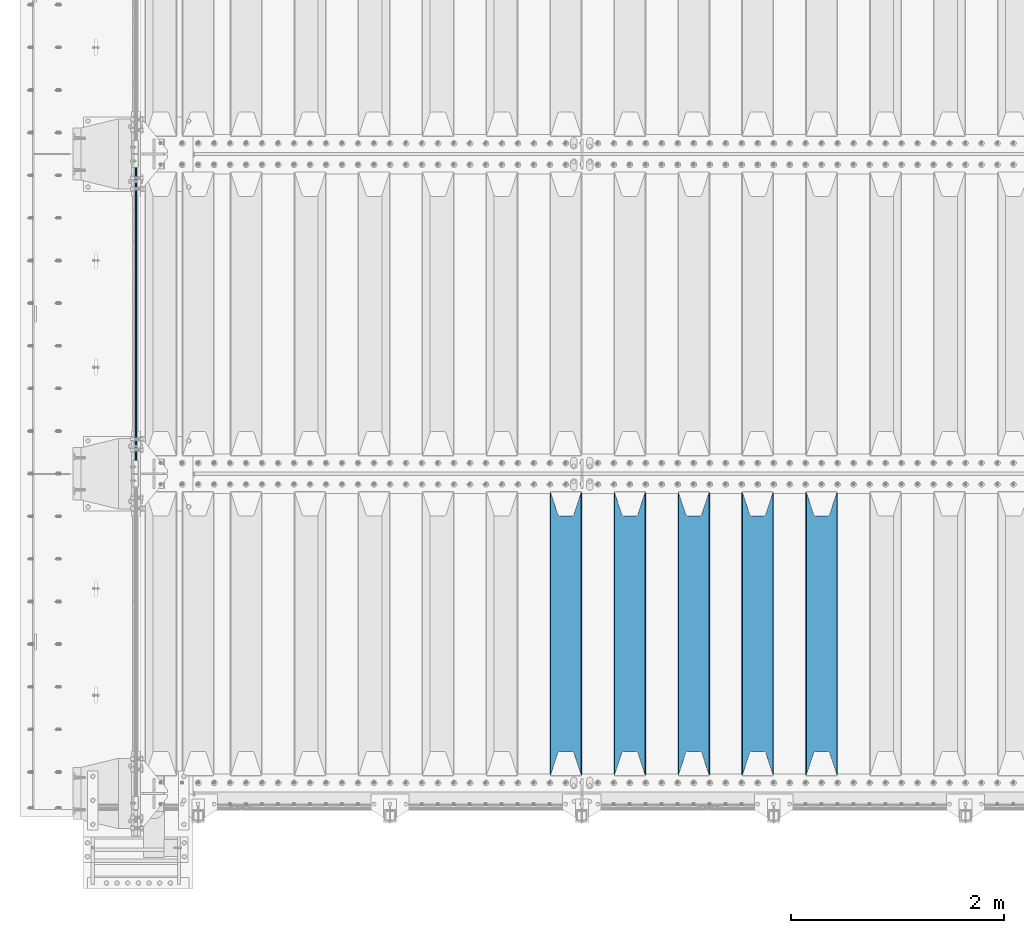
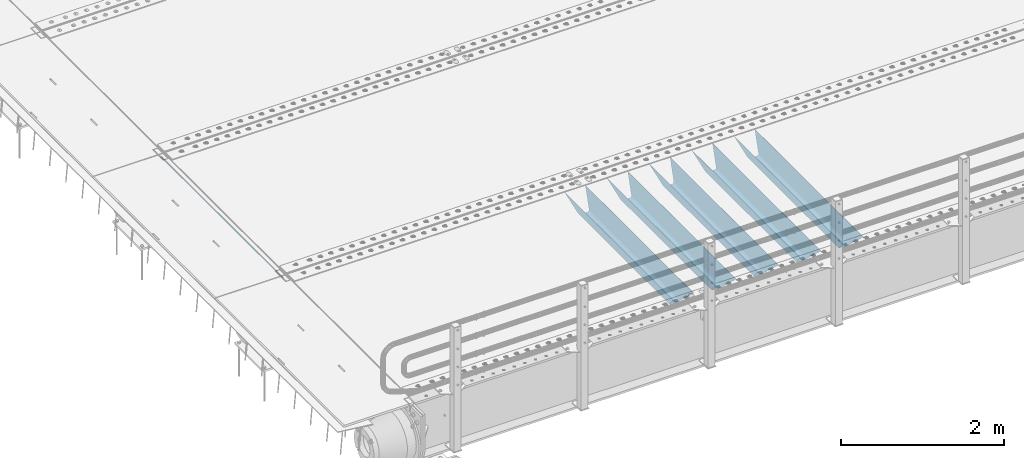
# One storey, part 101 of 240: 6 beams.
"""IFC2X3 building model written with IfcOpenShell, lengths in millimetres."""

from ifc_helpers import new_model, si_unit, frame, origin_with_axes, place, context, subcontext, project, spatial, faceted_brep, material, type_object, element, save


model = new_model("IFC2X3")

# Units and contexts
model_context = context("Model", 3, precision=1e-05, world=origin_with_axes())
body_context = subcontext(model_context, "Body", "Model", "MODEL_VIEW")
ifc_project = project(units=[si_unit("LENGTHUNIT", "METRE", prefix="MILLI"), si_unit("AREAUNIT", "SQUARE_METRE"), si_unit("VOLUMEUNIT", "CUBIC_METRE"), si_unit("MASSUNIT", "GRAM", prefix="KILO"), si_unit("TIMEUNIT", "SECOND"), si_unit("PLANEANGLEUNIT", "RADIAN"), si_unit("SOLIDANGLEUNIT", "STERADIAN"), si_unit("THERMODYNAMICTEMPERATUREUNIT", "DEGREE_CELSIUS"), si_unit("LUMINOUSINTENSITYUNIT", "LUMEN")], contexts=[model_context])

# Site, building, storey
site_placement = place(None, origin_with_axes())
site = spatial("IfcSite", under=ifc_project, at=site_placement, CompositionType="ELEMENT")
building_placement = place(site_placement, origin_with_axes())
building = spatial("IfcBuilding", under=site, at=building_placement, Name="Standard", CompositionType="ELEMENT")
storey_placement = place(building_placement, origin_with_axes())
storey = spatial("IfcBuildingStorey", under=building, at=storey_placement, Name="Undefined", CompositionType="ELEMENT", Elevation=0.0)

# Beams
ifc_material = material(Name="STEEL/S355N")
beam_type_1 = type_object("IfcBeamType", Name="D20", PredefinedType="NOTDEFINED")
beam_1_placement = place(storey_placement, frame((42415.0, 27004.9999999999, -26.0000182195434), z_axis=(0.0, 0.0, 1.0), x_axis=(0.0, 1.0, 0.0)))
element("IfcBeam", 1, at=beam_1_placement, inside=storey, type_object=beam_type_1, material=ifc_material, ObjectType="D20", context=body_context, shape_type="Brep", body=[
    faceted_brep([(0.0, -10.0, 0.0), (0.0, -7.07106781186303, -7.07106781186548), (2990.0, -7.07106781186303, -7.07106781186548), (2990.0, -10.0, 0.0), (0.0, 0.0, -10.0), (2990.0, 0.0, -10.0), (0.0, 7.07106781186303, -7.07106781186547), (2990.0, 7.07106781186303, -7.07106781186547), (0.0, 10.0, 0.0), (2990.0, 10.0, 0.0), (0.0, 7.07106781186303, 7.07106781186548), (2990.0, 7.07106781186303, 7.07106781186548), (0.0, 0.0, 10.0), (2990.0, 0.0, 10.0), (0.0, -7.07106781186303, 7.07106781186548), (2990.0, -7.07106781186303, 7.07106781186548)], [[[0, 1, 2, 3]], [[1, 4, 5, 2]], [[4, 6, 7, 5]], [[6, 8, 9, 7]], [[8, 10, 11, 9]], [[10, 12, 13, 11]], [[12, 14, 15, 13]], [[14, 0, 3, 15]], [[5, 7, 9, 11, 13, 15, 3, 2]], [[14, 12, 10, 8, 6, 4, 1, 0]]]),
])
beam_type_2 = type_object("IfcBeamType", PredefinedType="NOTDEFINED")
beam_2_placement = place(storey_placement, frame((48850.0, 24175.0, -115.0), z_axis=(0.0, 0.0, 1.0), x_axis=(0.0, 1.0, 0.0)))
element("IfcBeam", 2, at=beam_2_placement, inside=storey, type_object=beam_type_2, material=ifc_material, context=body_context, shape_type="Brep", body=[
    faceted_brep([(0.0, 150.0, 115.0), (0.0, 143.690000000002, 115.0), (2650.00000000297, 143.690000000002, 115.0), (2650.00000000297, 150.0, 115.0), (2650.00000000297, 142.059565218406, 110.000000003094), (2650.00000000297, 148.369565218403, 110.000000003094), (2441.90079219209, -80.1103600731149, -98.0992078077845), (2437.7588105432, -77.5672621345584, -102.241189456673), (2434.06523489747, -74.4080125315522, -105.934765102404), (2430.9108609509, -70.7102721255724, -109.089139048974), (2428.37322971128, -66.5649389910031, -111.626770288588), (2426.51472138055, -62.0739139532889, -113.485278619323), (2425.38102192092, -57.3475956567636, -114.618978078955), (2424.99999999987, -52.5021667386536, -115.0), (2424.99999999987, 52.5021667386536, -115.0), (2425.38102192092, 57.3475956567636, -114.618978078955), (2426.51472138055, 62.0739139532889, -113.485278619323), (2428.37322971128, 66.5649389910031, -111.626770288588), (2430.9108609509, 70.7102721255724, -109.089139048974), (2434.06523489747, 74.4080125315522, -105.934765102404), (2437.7588105432, 77.5672621345584, -102.241189456673), (2441.90079219209, 80.1103600731149, -98.0992078077846), (2446.38936140512, 81.9747917625791, -93.6106385947584), (2448.2494850041, 76.2713538057287, -91.7505149957729), (2444.62967112263, 74.76777986261, -95.3703288772456), (2441.28936334127, 72.7168944282894, -98.710636658607), (2438.31067330439, 70.1691124903809, -101.689326695487), (2435.76682334748, 67.1870637758839, -104.233176652398), (2433.72034654134, 63.8440531834931, -106.279653458539), (2432.22154950042, 60.2222587982324, -107.778450499454), (2431.30727574265, 56.4107117849126, -108.692724257221), (2430.99999999987, 52.5031078186876, -109.0), (2430.99999999987, -52.5031078186876, -109.0), (2431.30727574265, -56.4107117849126, -108.692724257221), (2432.22154950042, -60.2222587982324, -107.778450499454), (2433.72034654134, -63.8440531834931, -106.279653458539), (2435.76682334748, -67.1870637758839, -104.233176652398), (2438.31067330439, -70.1691124903809, -101.689326695487), (2441.28936334127, -72.7168944282894, -98.7106366586071), (2444.62967112263, -74.76777986261, -95.3703288772457), (2448.2494850041, -76.2713538057287, -91.7505149957729), (2650.00000000297, -142.059565218406, 110.000000003094), (2650.00000000297, -148.369565218403, 110.000000003094), (2446.38936140512, -81.9747917625791, -93.6106385947584), (2650.00000000297, -143.690000000002, 115.0), (2650.00000000297, -150.0, 115.0), (0.0, -143.690000000002, 115.0), (0.0, -150.0, 115.0), (0.0, -148.369565218258, 110.000000002667), (203.610638597427, -81.9747917625791, -93.6106385947584), (208.09920781045, -80.1103600731149, -98.0992078077845), (212.241189459342, -77.5672621345584, -102.241189456673), (215.93476510507, -74.4080125315522, -105.934765102404), (219.089139051641, -70.7102721255724, -109.089139048974), (221.626770291256, -66.5649389910031, -111.626770288588), (223.485278621989, -62.0739139532889, -113.485278619323), (224.618978081624, -57.3475956567636, -114.618978078955), (225.000000002663, -52.5021667386536, -115.0), (225.000000002663, 52.5021667386536, -115.0), (224.618978081624, 57.3475956567636, -114.618978078955), (223.485278621989, 62.0739139532889, -113.485278619323), (221.626770291256, 66.5649389910031, -111.626770288588), (219.089139051641, 70.7102721255724, -109.089139048974), (215.93476510507, 74.4080125315522, -105.934765102404), (212.241189459342, 77.5672621345584, -102.241189456673), (208.09920781045, 80.1103600731149, -98.0992078077846), (203.610638597427, 81.9747917625791, -93.6106385947584), (0.0, 148.369565218258, 110.000000002667), (0.0, 142.05956521826, 110.000000002667), (201.750514998439, 76.2713538057287, -91.7505149957729), (205.370328879908, 74.76777986261, -95.3703288772456), (208.710636661275, 72.7168944282894, -98.710636658607), (211.689326698153, 70.1691124903809, -101.689326695487), (214.233176655063, 67.1870637758839, -104.233176652398), (216.279653461206, 63.8440531834931, -106.279653458539), (217.778450502123, 60.2222587982324, -107.778450499454), (218.692724259887, 56.4107117849126, -108.692724257221), (219.000000002667, 52.5031078186876, -109.0), (219.000000002667, -52.5031078186876, -109.0), (218.692724259887, -56.4107117849126, -108.692724257221), (217.778450502123, -60.2222587982324, -107.778450499454), (216.279653461206, -63.8440531834931, -106.279653458539), (214.233176655063, -67.1870637758839, -104.233176652398), (211.689326698153, -70.1691124903809, -101.689326695487), (208.710636661275, -72.7168944282894, -98.7106366586071), (205.370328879915, -74.76777986261, -95.3703288772457), (201.750514998439, -76.2713538057287, -91.7505149957729), (0.0, -142.05956521826, 110.000000002667)], [[[0, 1, 2, 3]], [[3, 2, 4, 5]], [[6, 7, 8, 9, 10, 11, 12, 13, 14, 15, 16, 17, 18, 19, 20, 21, 22, 5, 4, 23, 24, 25, 26, 27, 28, 29, 30, 31, 32, 33, 34, 35, 36, 37, 38, 39, 40, 41, 42, 43]], [[44, 45, 42, 41]], [[46, 47, 45, 44]], [[43, 42, 45, 47, 48, 49]], [[6, 43, 49, 50]], [[7, 6, 50, 51]], [[8, 7, 51, 52]], [[9, 8, 52, 53]], [[10, 9, 53, 54]], [[11, 10, 54, 55]], [[12, 11, 55, 56]], [[13, 12, 56, 57]], [[14, 13, 57, 58]], [[15, 14, 58, 59]], [[16, 15, 59, 60]], [[17, 16, 60, 61]], [[18, 17, 61, 62]], [[19, 18, 62, 63]], [[20, 19, 63, 64]], [[21, 20, 64, 65]], [[22, 21, 65, 66]], [[0, 3, 5, 22, 66, 67]], [[1, 0, 67, 68]], [[23, 4, 2, 1, 68, 69]], [[24, 23, 69, 70]], [[25, 24, 70, 71]], [[26, 25, 71, 72]], [[27, 26, 72, 73]], [[28, 27, 73, 74]], [[29, 28, 74, 75]], [[30, 29, 75, 76]], [[31, 30, 76, 77]], [[32, 31, 77, 78]], [[33, 32, 78, 79]], [[34, 33, 79, 80]], [[35, 34, 80, 81]], [[36, 35, 81, 82]], [[37, 36, 82, 83]], [[38, 37, 83, 84]], [[39, 38, 84, 85]], [[40, 39, 85, 86]], [[46, 44, 41, 40, 86, 87]], [[47, 46, 87, 48]], [[86, 85, 84, 83, 82, 81, 80, 79, 78, 77, 76, 75, 74, 73, 72, 71, 70, 69, 68, 67, 66, 65, 64, 63, 62, 61, 60, 59, 58, 57, 56, 55, 54, 53, 52, 51, 50, 49, 48, 87]]]),
])
beam_3_placement = place(storey_placement, frame((48250.0, 24175.0, -115.0), z_axis=(0.0, 0.0, 1.0), x_axis=(0.0, 1.0, 0.0)))
element("IfcBeam", 3, at=beam_3_placement, inside=storey, type_object=beam_type_2, material=ifc_material, context=body_context, shape_type="Brep", body=[
    faceted_brep([(0.0, 150.0, 115.0), (0.0, 143.690000000002, 115.0), (2650.00000000297, 143.690000000002, 115.0), (2650.00000000297, 150.0, 115.0), (2650.00000000297, 142.059565218406, 110.000000003094), (2650.00000000297, 148.369565218403, 110.000000003094), (2441.90079219209, -80.1103600731149, -98.0992078077845), (2437.7588105432, -77.5672621345584, -102.241189456673), (2434.06523489747, -74.4080125315522, -105.934765102404), (2430.9108609509, -70.7102721255724, -109.089139048974), (2428.37322971128, -66.5649389910031, -111.626770288588), (2426.51472138055, -62.0739139532889, -113.485278619323), (2425.38102192092, -57.3475956567636, -114.618978078955), (2424.99999999987, -52.5021667386536, -115.0), (2424.99999999987, 52.5021667386536, -115.0), (2425.38102192092, 57.3475956567636, -114.618978078955), (2426.51472138055, 62.0739139532889, -113.485278619323), (2428.37322971128, 66.5649389910031, -111.626770288588), (2430.9108609509, 70.7102721255724, -109.089139048974), (2434.06523489747, 74.4080125315522, -105.934765102404), (2437.7588105432, 77.5672621345584, -102.241189456673), (2441.90079219209, 80.1103600731149, -98.0992078077846), (2446.38936140512, 81.9747917625791, -93.6106385947584), (2448.2494850041, 76.2713538057287, -91.7505149957729), (2444.62967112263, 74.76777986261, -95.3703288772456), (2441.28936334127, 72.7168944282894, -98.710636658607), (2438.31067330439, 70.1691124903809, -101.689326695487), (2435.76682334748, 67.1870637758839, -104.233176652398), (2433.72034654134, 63.8440531834931, -106.279653458539), (2432.22154950042, 60.2222587982324, -107.778450499454), (2431.30727574265, 56.4107117849126, -108.692724257221), (2430.99999999987, 52.5031078186876, -109.0), (2430.99999999987, -52.5031078186876, -109.0), (2431.30727574265, -56.4107117849126, -108.692724257221), (2432.22154950042, -60.2222587982324, -107.778450499454), (2433.72034654134, -63.8440531834931, -106.279653458539), (2435.76682334748, -67.1870637758839, -104.233176652398), (2438.31067330439, -70.1691124903809, -101.689326695487), (2441.28936334127, -72.7168944282894, -98.7106366586071), (2444.62967112263, -74.76777986261, -95.3703288772457), (2448.2494850041, -76.2713538057287, -91.7505149957729), (2650.00000000297, -142.059565218406, 110.000000003094), (2650.00000000297, -148.369565218403, 110.000000003094), (2446.38936140512, -81.9747917625791, -93.6106385947584), (2650.00000000297, -143.690000000002, 115.0), (2650.00000000297, -150.0, 115.0), (0.0, -143.690000000002, 115.0), (0.0, -150.0, 115.0), (0.0, -148.369565218258, 110.000000002667), (203.610638597427, -81.9747917625791, -93.6106385947584), (208.09920781045, -80.1103600731149, -98.0992078077845), (212.241189459342, -77.5672621345584, -102.241189456673), (215.93476510507, -74.4080125315522, -105.934765102404), (219.089139051641, -70.7102721255724, -109.089139048974), (221.626770291256, -66.5649389910031, -111.626770288588), (223.485278621989, -62.0739139532889, -113.485278619323), (224.618978081624, -57.3475956567636, -114.618978078955), (225.000000002663, -52.5021667386536, -115.0), (225.000000002663, 52.5021667386536, -115.0), (224.618978081624, 57.3475956567636, -114.618978078955), (223.485278621989, 62.0739139532889, -113.485278619323), (221.626770291256, 66.5649389910031, -111.626770288588), (219.089139051641, 70.7102721255724, -109.089139048974), (215.93476510507, 74.4080125315522, -105.934765102404), (212.241189459342, 77.5672621345584, -102.241189456673), (208.09920781045, 80.1103600731149, -98.0992078077846), (203.610638597427, 81.9747917625791, -93.6106385947584), (0.0, 148.369565218258, 110.000000002667), (0.0, 142.05956521826, 110.000000002667), (201.750514998439, 76.2713538057287, -91.7505149957729), (205.370328879908, 74.76777986261, -95.3703288772456), (208.710636661275, 72.7168944282894, -98.710636658607), (211.689326698153, 70.1691124903809, -101.689326695487), (214.233176655063, 67.1870637758839, -104.233176652398), (216.279653461206, 63.8440531834931, -106.279653458539), (217.778450502123, 60.2222587982324, -107.778450499454), (218.692724259887, 56.4107117849126, -108.692724257221), (219.000000002667, 52.5031078186876, -109.0), (219.000000002667, -52.5031078186876, -109.0), (218.692724259887, -56.4107117849126, -108.692724257221), (217.778450502123, -60.2222587982324, -107.778450499454), (216.279653461206, -63.8440531834931, -106.279653458539), (214.233176655063, -67.1870637758839, -104.233176652398), (211.689326698153, -70.1691124903809, -101.689326695487), (208.710636661275, -72.7168944282894, -98.7106366586071), (205.370328879915, -74.76777986261, -95.3703288772457), (201.750514998439, -76.2713538057287, -91.7505149957729), (0.0, -142.05956521826, 110.000000002667)], [[[0, 1, 2, 3]], [[3, 2, 4, 5]], [[6, 7, 8, 9, 10, 11, 12, 13, 14, 15, 16, 17, 18, 19, 20, 21, 22, 5, 4, 23, 24, 25, 26, 27, 28, 29, 30, 31, 32, 33, 34, 35, 36, 37, 38, 39, 40, 41, 42, 43]], [[44, 45, 42, 41]], [[46, 47, 45, 44]], [[43, 42, 45, 47, 48, 49]], [[6, 43, 49, 50]], [[7, 6, 50, 51]], [[8, 7, 51, 52]], [[9, 8, 52, 53]], [[10, 9, 53, 54]], [[11, 10, 54, 55]], [[12, 11, 55, 56]], [[13, 12, 56, 57]], [[14, 13, 57, 58]], [[15, 14, 58, 59]], [[16, 15, 59, 60]], [[17, 16, 60, 61]], [[18, 17, 61, 62]], [[19, 18, 62, 63]], [[20, 19, 63, 64]], [[21, 20, 64, 65]], [[22, 21, 65, 66]], [[0, 3, 5, 22, 66, 67]], [[1, 0, 67, 68]], [[23, 4, 2, 1, 68, 69]], [[24, 23, 69, 70]], [[25, 24, 70, 71]], [[26, 25, 71, 72]], [[27, 26, 72, 73]], [[28, 27, 73, 74]], [[29, 28, 74, 75]], [[30, 29, 75, 76]], [[31, 30, 76, 77]], [[32, 31, 77, 78]], [[33, 32, 78, 79]], [[34, 33, 79, 80]], [[35, 34, 80, 81]], [[36, 35, 81, 82]], [[37, 36, 82, 83]], [[38, 37, 83, 84]], [[39, 38, 84, 85]], [[40, 39, 85, 86]], [[46, 44, 41, 40, 86, 87]], [[47, 46, 87, 48]], [[86, 85, 84, 83, 82, 81, 80, 79, 78, 77, 76, 75, 74, 73, 72, 71, 70, 69, 68, 67, 66, 65, 64, 63, 62, 61, 60, 59, 58, 57, 56, 55, 54, 53, 52, 51, 50, 49, 48, 87]]]),
])
beam_4_placement = place(storey_placement, frame((47650.0, 24175.0, -115.0), z_axis=(0.0, 0.0, 1.0), x_axis=(0.0, 1.0, 0.0)))
element("IfcBeam", 4, at=beam_4_placement, inside=storey, type_object=beam_type_2, material=ifc_material, context=body_context, shape_type="Brep", body=[
    faceted_brep([(0.0, 150.0, 115.0), (0.0, 143.690000000002, 115.0), (2650.00000000297, 143.690000000002, 115.0), (2650.00000000297, 150.0, 115.0), (2650.00000000297, 142.059565218406, 110.000000003094), (2650.00000000297, 148.369565218403, 110.000000003094), (2441.90079219209, -80.1103600731149, -98.0992078077845), (2437.7588105432, -77.5672621345584, -102.241189456673), (2434.06523489747, -74.4080125315522, -105.934765102404), (2430.9108609509, -70.7102721255724, -109.089139048974), (2428.37322971128, -66.5649389910031, -111.626770288588), (2426.51472138055, -62.0739139532889, -113.485278619323), (2425.38102192092, -57.3475956567636, -114.618978078955), (2424.99999999987, -52.5021667386536, -115.0), (2424.99999999987, 52.5021667386536, -115.0), (2425.38102192092, 57.3475956567636, -114.618978078955), (2426.51472138055, 62.0739139532889, -113.485278619323), (2428.37322971128, 66.5649389910031, -111.626770288588), (2430.9108609509, 70.7102721255724, -109.089139048974), (2434.06523489747, 74.4080125315522, -105.934765102404), (2437.7588105432, 77.5672621345584, -102.241189456673), (2441.90079219209, 80.1103600731149, -98.0992078077846), (2446.38936140512, 81.9747917625791, -93.6106385947584), (2448.2494850041, 76.2713538057287, -91.7505149957729), (2444.62967112263, 74.76777986261, -95.3703288772456), (2441.28936334127, 72.7168944282894, -98.710636658607), (2438.31067330439, 70.1691124903809, -101.689326695487), (2435.76682334748, 67.1870637758839, -104.233176652398), (2433.72034654134, 63.8440531834931, -106.279653458539), (2432.22154950042, 60.2222587982324, -107.778450499454), (2431.30727574265, 56.4107117849126, -108.692724257221), (2430.99999999987, 52.5031078186876, -109.0), (2430.99999999987, -52.5031078186876, -109.0), (2431.30727574265, -56.4107117849126, -108.692724257221), (2432.22154950042, -60.2222587982324, -107.778450499454), (2433.72034654134, -63.8440531834931, -106.279653458539), (2435.76682334748, -67.1870637758839, -104.233176652398), (2438.31067330439, -70.1691124903809, -101.689326695487), (2441.28936334127, -72.7168944282894, -98.7106366586071), (2444.62967112263, -74.76777986261, -95.3703288772457), (2448.2494850041, -76.2713538057287, -91.7505149957729), (2650.00000000297, -142.059565218406, 110.000000003094), (2650.00000000297, -148.369565218403, 110.000000003094), (2446.38936140512, -81.9747917625791, -93.6106385947584), (2650.00000000297, -143.690000000002, 115.0), (2650.00000000297, -150.0, 115.0), (0.0, -143.690000000002, 115.0), (0.0, -150.0, 115.0), (0.0, -148.369565218258, 110.000000002667), (203.610638597427, -81.9747917625791, -93.6106385947584), (208.09920781045, -80.1103600731149, -98.0992078077845), (212.241189459342, -77.5672621345584, -102.241189456673), (215.93476510507, -74.4080125315522, -105.934765102404), (219.089139051641, -70.7102721255724, -109.089139048974), (221.626770291256, -66.5649389910031, -111.626770288588), (223.485278621989, -62.0739139532889, -113.485278619323), (224.618978081624, -57.3475956567636, -114.618978078955), (225.000000002663, -52.5021667386536, -115.0), (225.000000002663, 52.5021667386536, -115.0), (224.618978081624, 57.3475956567636, -114.618978078955), (223.485278621989, 62.0739139532889, -113.485278619323), (221.626770291256, 66.5649389910031, -111.626770288588), (219.089139051641, 70.7102721255724, -109.089139048974), (215.93476510507, 74.4080125315522, -105.934765102404), (212.241189459342, 77.5672621345584, -102.241189456673), (208.09920781045, 80.1103600731149, -98.0992078077846), (203.610638597427, 81.9747917625791, -93.6106385947584), (0.0, 148.369565218258, 110.000000002667), (0.0, 142.05956521826, 110.000000002667), (201.750514998439, 76.2713538057287, -91.7505149957729), (205.370328879908, 74.76777986261, -95.3703288772456), (208.710636661275, 72.7168944282894, -98.710636658607), (211.689326698153, 70.1691124903809, -101.689326695487), (214.233176655063, 67.1870637758839, -104.233176652398), (216.279653461206, 63.8440531834931, -106.279653458539), (217.778450502123, 60.2222587982324, -107.778450499454), (218.692724259887, 56.4107117849126, -108.692724257221), (219.000000002667, 52.5031078186876, -109.0), (219.000000002667, -52.5031078186876, -109.0), (218.692724259887, -56.4107117849126, -108.692724257221), (217.778450502123, -60.2222587982324, -107.778450499454), (216.279653461206, -63.8440531834931, -106.279653458539), (214.233176655063, -67.1870637758839, -104.233176652398), (211.689326698153, -70.1691124903809, -101.689326695487), (208.710636661275, -72.7168944282894, -98.7106366586071), (205.370328879915, -74.76777986261, -95.3703288772457), (201.750514998439, -76.2713538057287, -91.7505149957729), (0.0, -142.05956521826, 110.000000002667)], [[[0, 1, 2, 3]], [[3, 2, 4, 5]], [[6, 7, 8, 9, 10, 11, 12, 13, 14, 15, 16, 17, 18, 19, 20, 21, 22, 5, 4, 23, 24, 25, 26, 27, 28, 29, 30, 31, 32, 33, 34, 35, 36, 37, 38, 39, 40, 41, 42, 43]], [[44, 45, 42, 41]], [[46, 47, 45, 44]], [[43, 42, 45, 47, 48, 49]], [[6, 43, 49, 50]], [[7, 6, 50, 51]], [[8, 7, 51, 52]], [[9, 8, 52, 53]], [[10, 9, 53, 54]], [[11, 10, 54, 55]], [[12, 11, 55, 56]], [[13, 12, 56, 57]], [[14, 13, 57, 58]], [[15, 14, 58, 59]], [[16, 15, 59, 60]], [[17, 16, 60, 61]], [[18, 17, 61, 62]], [[19, 18, 62, 63]], [[20, 19, 63, 64]], [[21, 20, 64, 65]], [[22, 21, 65, 66]], [[0, 3, 5, 22, 66, 67]], [[1, 0, 67, 68]], [[23, 4, 2, 1, 68, 69]], [[24, 23, 69, 70]], [[25, 24, 70, 71]], [[26, 25, 71, 72]], [[27, 26, 72, 73]], [[28, 27, 73, 74]], [[29, 28, 74, 75]], [[30, 29, 75, 76]], [[31, 30, 76, 77]], [[32, 31, 77, 78]], [[33, 32, 78, 79]], [[34, 33, 79, 80]], [[35, 34, 80, 81]], [[36, 35, 81, 82]], [[37, 36, 82, 83]], [[38, 37, 83, 84]], [[39, 38, 84, 85]], [[40, 39, 85, 86]], [[46, 44, 41, 40, 86, 87]], [[47, 46, 87, 48]], [[86, 85, 84, 83, 82, 81, 80, 79, 78, 77, 76, 75, 74, 73, 72, 71, 70, 69, 68, 67, 66, 65, 64, 63, 62, 61, 60, 59, 58, 57, 56, 55, 54, 53, 52, 51, 50, 49, 48, 87]]]),
])
beam_5_placement = place(storey_placement, frame((47050.0, 24175.0, -115.0), z_axis=(0.0, 0.0, 1.0), x_axis=(0.0, 1.0, 0.0)))
element("IfcBeam", 5, at=beam_5_placement, inside=storey, type_object=beam_type_2, material=ifc_material, context=body_context, shape_type="Brep", body=[
    faceted_brep([(0.0, 150.0, 115.0), (0.0, 143.690000000002, 115.0), (2650.00000000297, 143.690000000002, 115.0), (2650.00000000297, 150.0, 115.0), (2650.00000000297, 142.059565218406, 110.000000003094), (2650.00000000297, 148.369565218403, 110.000000003094), (2441.90079219209, -80.1103600731149, -98.0992078077845), (2437.7588105432, -77.5672621345584, -102.241189456673), (2434.06523489747, -74.4080125315522, -105.934765102404), (2430.9108609509, -70.7102721255724, -109.089139048974), (2428.37322971128, -66.5649389910031, -111.626770288588), (2426.51472138055, -62.0739139532889, -113.485278619323), (2425.38102192092, -57.3475956567636, -114.618978078955), (2424.99999999987, -52.5021667386536, -115.0), (2424.99999999987, 52.5021667386536, -115.0), (2425.38102192092, 57.3475956567636, -114.618978078955), (2426.51472138055, 62.0739139532889, -113.485278619323), (2428.37322971128, 66.5649389910031, -111.626770288588), (2430.9108609509, 70.7102721255724, -109.089139048974), (2434.06523489747, 74.4080125315522, -105.934765102404), (2437.7588105432, 77.5672621345584, -102.241189456673), (2441.90079219209, 80.1103600731149, -98.0992078077846), (2446.38936140512, 81.9747917625791, -93.6106385947584), (2448.2494850041, 76.2713538057287, -91.7505149957729), (2444.62967112263, 74.76777986261, -95.3703288772456), (2441.28936334127, 72.7168944282894, -98.710636658607), (2438.31067330439, 70.1691124903809, -101.689326695487), (2435.76682334748, 67.1870637758839, -104.233176652398), (2433.72034654134, 63.8440531834931, -106.279653458539), (2432.22154950042, 60.2222587982324, -107.778450499454), (2431.30727574265, 56.4107117849126, -108.692724257221), (2430.99999999987, 52.5031078186876, -109.0), (2430.99999999987, -52.5031078186876, -109.0), (2431.30727574265, -56.4107117849126, -108.692724257221), (2432.22154950042, -60.2222587982324, -107.778450499454), (2433.72034654134, -63.8440531834931, -106.279653458539), (2435.76682334748, -67.1870637758839, -104.233176652398), (2438.31067330439, -70.1691124903809, -101.689326695487), (2441.28936334127, -72.7168944282894, -98.7106366586071), (2444.62967112263, -74.76777986261, -95.3703288772457), (2448.2494850041, -76.2713538057287, -91.7505149957729), (2650.00000000297, -142.059565218406, 110.000000003094), (2650.00000000297, -148.369565218403, 110.000000003094), (2446.38936140512, -81.9747917625791, -93.6106385947584), (2650.00000000297, -143.690000000002, 115.0), (2650.00000000297, -150.0, 115.0), (0.0, -143.690000000002, 115.0), (0.0, -150.0, 115.0), (0.0, -148.369565218258, 110.000000002667), (203.610638597427, -81.9747917625791, -93.6106385947584), (208.09920781045, -80.1103600731149, -98.0992078077845), (212.241189459342, -77.5672621345584, -102.241189456673), (215.93476510507, -74.4080125315522, -105.934765102404), (219.089139051641, -70.7102721255724, -109.089139048974), (221.626770291256, -66.5649389910031, -111.626770288588), (223.485278621989, -62.0739139532889, -113.485278619323), (224.618978081624, -57.3475956567636, -114.618978078955), (225.000000002663, -52.5021667386536, -115.0), (225.000000002663, 52.5021667386536, -115.0), (224.618978081624, 57.3475956567636, -114.618978078955), (223.485278621989, 62.0739139532889, -113.485278619323), (221.626770291256, 66.5649389910031, -111.626770288588), (219.089139051641, 70.7102721255724, -109.089139048974), (215.93476510507, 74.4080125315522, -105.934765102404), (212.241189459342, 77.5672621345584, -102.241189456673), (208.09920781045, 80.1103600731149, -98.0992078077846), (203.610638597427, 81.9747917625791, -93.6106385947584), (0.0, 148.369565218258, 110.000000002667), (0.0, 142.05956521826, 110.000000002667), (201.750514998439, 76.2713538057287, -91.7505149957729), (205.370328879908, 74.76777986261, -95.3703288772456), (208.710636661275, 72.7168944282894, -98.710636658607), (211.689326698153, 70.1691124903809, -101.689326695487), (214.233176655063, 67.1870637758839, -104.233176652398), (216.279653461206, 63.8440531834931, -106.279653458539), (217.778450502123, 60.2222587982324, -107.778450499454), (218.692724259887, 56.4107117849126, -108.692724257221), (219.000000002667, 52.5031078186876, -109.0), (219.000000002667, -52.5031078186876, -109.0), (218.692724259887, -56.4107117849126, -108.692724257221), (217.778450502123, -60.2222587982324, -107.778450499454), (216.279653461206, -63.8440531834931, -106.279653458539), (214.233176655063, -67.1870637758839, -104.233176652398), (211.689326698153, -70.1691124903809, -101.689326695487), (208.710636661275, -72.7168944282894, -98.7106366586071), (205.370328879915, -74.76777986261, -95.3703288772457), (201.750514998439, -76.2713538057287, -91.7505149957729), (0.0, -142.05956521826, 110.000000002667)], [[[0, 1, 2, 3]], [[3, 2, 4, 5]], [[6, 7, 8, 9, 10, 11, 12, 13, 14, 15, 16, 17, 18, 19, 20, 21, 22, 5, 4, 23, 24, 25, 26, 27, 28, 29, 30, 31, 32, 33, 34, 35, 36, 37, 38, 39, 40, 41, 42, 43]], [[44, 45, 42, 41]], [[46, 47, 45, 44]], [[43, 42, 45, 47, 48, 49]], [[6, 43, 49, 50]], [[7, 6, 50, 51]], [[8, 7, 51, 52]], [[9, 8, 52, 53]], [[10, 9, 53, 54]], [[11, 10, 54, 55]], [[12, 11, 55, 56]], [[13, 12, 56, 57]], [[14, 13, 57, 58]], [[15, 14, 58, 59]], [[16, 15, 59, 60]], [[17, 16, 60, 61]], [[18, 17, 61, 62]], [[19, 18, 62, 63]], [[20, 19, 63, 64]], [[21, 20, 64, 65]], [[22, 21, 65, 66]], [[0, 3, 5, 22, 66, 67]], [[1, 0, 67, 68]], [[23, 4, 2, 1, 68, 69]], [[24, 23, 69, 70]], [[25, 24, 70, 71]], [[26, 25, 71, 72]], [[27, 26, 72, 73]], [[28, 27, 73, 74]], [[29, 28, 74, 75]], [[30, 29, 75, 76]], [[31, 30, 76, 77]], [[32, 31, 77, 78]], [[33, 32, 78, 79]], [[34, 33, 79, 80]], [[35, 34, 80, 81]], [[36, 35, 81, 82]], [[37, 36, 82, 83]], [[38, 37, 83, 84]], [[39, 38, 84, 85]], [[40, 39, 85, 86]], [[46, 44, 41, 40, 86, 87]], [[47, 46, 87, 48]], [[86, 85, 84, 83, 82, 81, 80, 79, 78, 77, 76, 75, 74, 73, 72, 71, 70, 69, 68, 67, 66, 65, 64, 63, 62, 61, 60, 59, 58, 57, 56, 55, 54, 53, 52, 51, 50, 49, 48, 87]]]),
])
beam_6_placement = place(storey_placement, frame((46450.0, 24175.0, -115.0), z_axis=(0.0, 0.0, 1.0), x_axis=(0.0, 1.0, 0.0)))
element("IfcBeam", 6, at=beam_6_placement, inside=storey, type_object=beam_type_2, material=ifc_material, context=body_context, shape_type="Brep", body=[
    faceted_brep([(0.0, 150.0, 115.0), (0.0, 143.690000000002, 115.0), (2650.00000000297, 143.690000000002, 115.0), (2650.00000000297, 150.0, 115.0), (2650.00000000297, 142.059565218406, 110.000000003094), (2650.00000000297, 148.369565218403, 110.000000003094), (2441.90079219209, -80.1103600731149, -98.0992078077845), (2437.7588105432, -77.5672621345584, -102.241189456673), (2434.06523489747, -74.4080125315522, -105.934765102404), (2430.9108609509, -70.7102721255724, -109.089139048974), (2428.37322971128, -66.5649389910031, -111.626770288588), (2426.51472138055, -62.0739139532889, -113.485278619323), (2425.38102192092, -57.3475956567636, -114.618978078955), (2424.99999999987, -52.5021667386536, -115.0), (2424.99999999987, 52.5021667386536, -115.0), (2425.38102192092, 57.3475956567636, -114.618978078955), (2426.51472138055, 62.0739139532889, -113.485278619323), (2428.37322971128, 66.5649389910031, -111.626770288588), (2430.9108609509, 70.7102721255724, -109.089139048974), (2434.06523489747, 74.4080125315522, -105.934765102404), (2437.7588105432, 77.5672621345584, -102.241189456673), (2441.90079219209, 80.1103600731149, -98.0992078077846), (2446.38936140512, 81.9747917625791, -93.6106385947584), (2448.2494850041, 76.2713538057287, -91.7505149957729), (2444.62967112263, 74.76777986261, -95.3703288772456), (2441.28936334127, 72.7168944282894, -98.710636658607), (2438.31067330439, 70.1691124903809, -101.689326695487), (2435.76682334748, 67.1870637758839, -104.233176652398), (2433.72034654134, 63.8440531834931, -106.279653458539), (2432.22154950042, 60.2222587982324, -107.778450499454), (2431.30727574265, 56.4107117849126, -108.692724257221), (2430.99999999987, 52.5031078186876, -109.0), (2430.99999999987, -52.5031078186876, -109.0), (2431.30727574265, -56.4107117849126, -108.692724257221), (2432.22154950042, -60.2222587982324, -107.778450499454), (2433.72034654134, -63.8440531834931, -106.279653458539), (2435.76682334748, -67.1870637758839, -104.233176652398), (2438.31067330439, -70.1691124903809, -101.689326695487), (2441.28936334127, -72.7168944282894, -98.7106366586071), (2444.62967112263, -74.76777986261, -95.3703288772457), (2448.2494850041, -76.2713538057287, -91.7505149957729), (2650.00000000297, -142.059565218406, 110.000000003094), (2650.00000000297, -148.369565218403, 110.000000003094), (2446.38936140512, -81.9747917625791, -93.6106385947584), (2650.00000000297, -143.690000000002, 115.0), (2650.00000000297, -150.0, 115.0), (0.0, -143.690000000002, 115.0), (0.0, -150.0, 115.0), (0.0, -148.369565218258, 110.000000002667), (203.610638597427, -81.9747917625791, -93.6106385947584), (208.09920781045, -80.1103600731149, -98.0992078077845), (212.241189459342, -77.5672621345584, -102.241189456673), (215.93476510507, -74.4080125315522, -105.934765102404), (219.089139051641, -70.7102721255724, -109.089139048974), (221.626770291256, -66.5649389910031, -111.626770288588), (223.485278621989, -62.0739139532889, -113.485278619323), (224.618978081624, -57.3475956567636, -114.618978078955), (225.000000002663, -52.5021667386536, -115.0), (225.000000002663, 52.5021667386536, -115.0), (224.618978081624, 57.3475956567636, -114.618978078955), (223.485278621989, 62.0739139532889, -113.485278619323), (221.626770291256, 66.5649389910031, -111.626770288588), (219.089139051641, 70.7102721255724, -109.089139048974), (215.93476510507, 74.4080125315522, -105.934765102404), (212.241189459342, 77.5672621345584, -102.241189456673), (208.09920781045, 80.1103600731149, -98.0992078077846), (203.610638597427, 81.9747917625791, -93.6106385947584), (0.0, 148.369565218258, 110.000000002667), (0.0, 142.05956521826, 110.000000002667), (201.750514998439, 76.2713538057287, -91.7505149957729), (205.370328879908, 74.76777986261, -95.3703288772456), (208.710636661275, 72.7168944282894, -98.710636658607), (211.689326698153, 70.1691124903809, -101.689326695487), (214.233176655063, 67.1870637758839, -104.233176652398), (216.279653461206, 63.8440531834931, -106.279653458539), (217.778450502123, 60.2222587982324, -107.778450499454), (218.692724259887, 56.4107117849126, -108.692724257221), (219.000000002667, 52.5031078186876, -109.0), (219.000000002667, -52.5031078186876, -109.0), (218.692724259887, -56.4107117849126, -108.692724257221), (217.778450502123, -60.2222587982324, -107.778450499454), (216.279653461206, -63.8440531834931, -106.279653458539), (214.233176655063, -67.1870637758839, -104.233176652398), (211.689326698153, -70.1691124903809, -101.689326695487), (208.710636661275, -72.7168944282894, -98.7106366586071), (205.370328879915, -74.76777986261, -95.3703288772457), (201.750514998439, -76.2713538057287, -91.7505149957729), (0.0, -142.05956521826, 110.000000002667)], [[[0, 1, 2, 3]], [[3, 2, 4, 5]], [[6, 7, 8, 9, 10, 11, 12, 13, 14, 15, 16, 17, 18, 19, 20, 21, 22, 5, 4, 23, 24, 25, 26, 27, 28, 29, 30, 31, 32, 33, 34, 35, 36, 37, 38, 39, 40, 41, 42, 43]], [[44, 45, 42, 41]], [[46, 47, 45, 44]], [[43, 42, 45, 47, 48, 49]], [[6, 43, 49, 50]], [[7, 6, 50, 51]], [[8, 7, 51, 52]], [[9, 8, 52, 53]], [[10, 9, 53, 54]], [[11, 10, 54, 55]], [[12, 11, 55, 56]], [[13, 12, 56, 57]], [[14, 13, 57, 58]], [[15, 14, 58, 59]], [[16, 15, 59, 60]], [[17, 16, 60, 61]], [[18, 17, 61, 62]], [[19, 18, 62, 63]], [[20, 19, 63, 64]], [[21, 20, 64, 65]], [[22, 21, 65, 66]], [[0, 3, 5, 22, 66, 67]], [[1, 0, 67, 68]], [[23, 4, 2, 1, 68, 69]], [[24, 23, 69, 70]], [[25, 24, 70, 71]], [[26, 25, 71, 72]], [[27, 26, 72, 73]], [[28, 27, 73, 74]], [[29, 28, 74, 75]], [[30, 29, 75, 76]], [[31, 30, 76, 77]], [[32, 31, 77, 78]], [[33, 32, 78, 79]], [[34, 33, 79, 80]], [[35, 34, 80, 81]], [[36, 35, 81, 82]], [[37, 36, 82, 83]], [[38, 37, 83, 84]], [[39, 38, 84, 85]], [[40, 39, 85, 86]], [[46, 44, 41, 40, 86, 87]], [[47, 46, 87, 48]], [[86, 85, 84, 83, 82, 81, 80, 79, 78, 77, 76, 75, 74, 73, 72, 71, 70, 69, 68, 67, 66, 65, 64, 63, 62, 61, 60, 59, 58, 57, 56, 55, 54, 53, 52, 51, 50, 49, 48, 87]]]),
])

save(model, "model.ifc")
